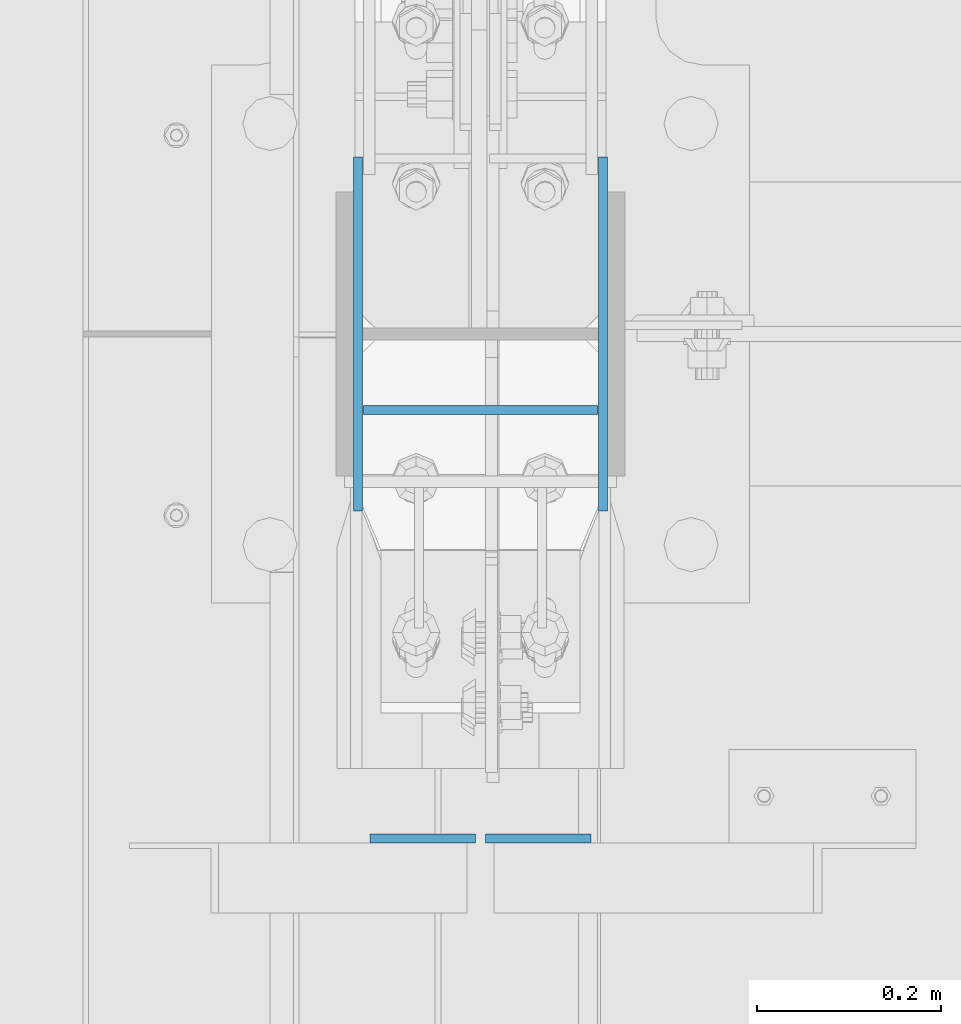
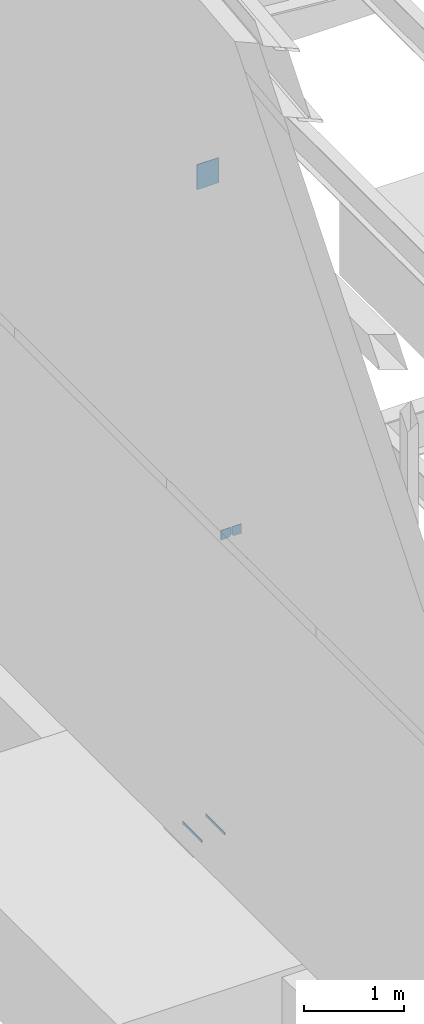
# One storey, part 387 of 1179: 5 columns, 3 elements without a shape of their own.
"""IFC2X3 building model written with IfcOpenShell, lengths in millimetres."""

from ifc_helpers import new_model, si_unit, frame, origin_with_axes, place, context, subcontext, project, spatial, faceted_brep, material, type_object, element, aggregate, save


model = new_model("IFC2X3")

# Units and contexts
model_context = context("Model", 3, precision=1e-05, world=origin_with_axes())
body_context = subcontext(model_context, "Body", "Model", "MODEL_VIEW")
ifc_project = project(units=[si_unit("LENGTHUNIT", "METRE", prefix="MILLI"), si_unit("AREAUNIT", "SQUARE_METRE"), si_unit("VOLUMEUNIT", "CUBIC_METRE"), si_unit("MASSUNIT", "GRAM", prefix="KILO"), si_unit("TIMEUNIT", "SECOND"), si_unit("PLANEANGLEUNIT", "RADIAN"), si_unit("SOLIDANGLEUNIT", "STERADIAN"), si_unit("THERMODYNAMICTEMPERATUREUNIT", "DEGREE_CELSIUS"), si_unit("LUMINOUSINTENSITYUNIT", "LUMEN")], contexts=[model_context])

# Site, building, storey
site_placement = place(None, origin_with_axes())
site = spatial("IfcSite", under=ifc_project, at=site_placement, CompositionType="ELEMENT")
building_placement = place(site_placement, origin_with_axes())
building = spatial("IfcBuilding", under=site, at=building_placement, Name="Undefined", CompositionType="ELEMENT")
storey_placement = place(building_placement, origin_with_axes())
storey = spatial("IfcBuildingStorey", under=building, at=storey_placement, Name="Undefined", CompositionType="ELEMENT", Elevation=0.0)

# Assembly, columns
assembly_1_placement = place(storey_placement, origin_with_axes())
assembly_1 = element("IfcElementAssembly", 1, at=assembly_1_placement, inside=storey, Name="BEAM", AssemblyPlace="NOTDEFINED", PredefinedType="RIGID_FRAME")
ifc_material_1 = material(Name="STEEL/A36")
column_type_1 = type_object("IfcColumnType", PredefinedType="NOTDEFINED")
column_1_placement = place(assembly_1_placement, frame((494.506249999995, 10933.1125, 3702.05), z_axis=(-1.0, 0.0, 0.0), x_axis=(0.0, 0.0, 1.0)))
column_1 = element("IfcColumn", 2, at=column_1_placement, type_object=column_type_1, material=ifc_material_1, Name="PLATE", context=body_context, shape_type="Brep", body=[
    faceted_brep([(22.2250000000004, 4.76250000000073, 57.1500000000015), (0.0, 4.76250000000073, 34.9249999999993), (0.0, -4.76250000000073, 34.9249999999993), (22.2250000000004, -4.76250000000073, 57.1500000000015), (114.300000000001, 4.76250000000073, 57.1500000000015), (114.300000000001, 4.76250000000073, -57.1500000000015), (0.0, 4.76250000000073, -57.1500000000015), (114.300000000001, -4.76250000000073, 57.1500000000015), (0.0, -4.76250000000073, -57.1500000000015), (114.300000000001, -4.76250000000073, -57.1500000000015)], [[[0, 1, 2, 3]], [[4, 5, 6, 1, 0]], [[7, 4, 0, 3]], [[8, 9, 7, 3, 2]], [[8, 6, 5, 9]], [[7, 9, 5, 4]], [[6, 8, 2, 1]]]),
])
column_2_placement = place(assembly_1_placement, frame((369.09375, 10933.1125, 3702.05), z_axis=(1.0, 0.0, 0.0), x_axis=(0.0, 0.0, 1.0)))
column_2 = element("IfcColumn", 3, at=column_2_placement, type_object=column_type_1, material=ifc_material_1, Name="PLATE", context=body_context, shape_type="Brep", body=[
    faceted_brep([(22.2250000000004, 4.76250000000073, 57.1500000000015), (0.0, 4.76250000000073, 34.9249999999993), (0.0, -4.76250000000073, 34.9249999999993), (22.2250000000004, -4.76250000000073, 57.1500000000015), (114.300000000001, 4.76250000000073, 57.1500000000015), (114.300000000001, 4.76250000000073, -57.1500000000015), (0.0, 4.76250000000073, -57.1500000000015), (114.300000000001, -4.76250000000073, 57.1500000000015), (0.0, -4.76250000000073, -57.1500000000015), (114.300000000001, -4.76250000000073, -57.1500000000015)], [[[0, 1, 2, 3]], [[4, 5, 6, 1, 0]], [[7, 4, 0, 3]], [[8, 9, 7, 3, 2]], [[8, 6, 5, 9]], [[7, 9, 5, 4]], [[6, 8, 2, 1]]]),
])
aggregate(assembly_1, [column_1, column_2])

assembly_2_placement = place(storey_placement, origin_with_axes())
assembly_2 = element("IfcElementAssembly", 4, at=assembly_2_placement, inside=storey, Name="COLUMN", AssemblyPlace="NOTDEFINED", PredefinedType="RIGID_FRAME")
ifc_material_2 = material(Name="STEEL/A572-GR.50")
column_type_2 = type_object("IfcColumnType", PredefinedType="NOTDEFINED")
column_3_placement = place(assembly_2_placement, frame((564.753000000002, 11480.8, -215.9), z_axis=(0.0, -1.0, 0.0), x_axis=(0.0, 0.0, 1.0)))
column_3 = element("IfcColumn", 5, at=column_3_placement, type_object=column_type_2, material=ifc_material_2, Name="PLATE", context=body_context, shape_type="Brep", body=[
    faceted_brep([(0.0, 4.76249999999982, -192.087500000001), (0.0, 4.76249999999982, 192.0875), (31.75, 4.76249999999982, 192.0875), (31.75, 4.76249999999982, -192.087500000001), (0.0, -4.76249999999982, 192.0875), (31.75, -4.76249999999982, 192.0875), (0.0, -4.76249999999982, -192.087500000001), (31.75, -4.76249999999982, -192.087500000001)], [[[0, 1, 2, 3]], [[1, 4, 5, 2]], [[4, 6, 7, 5]], [[6, 0, 3, 7]], [[5, 7, 3, 2]], [[6, 4, 1, 0]]]),
])
column_4_placement = place(assembly_2_placement, frame((298.846874999999, 11480.8, -215.9), z_axis=(0.0, -1.0, 0.0), x_axis=(0.0, 0.0, 1.0)))
column_4 = element("IfcColumn", 6, at=column_4_placement, type_object=column_type_2, material=ifc_material_2, Name="PLATE", context=body_context, shape_type="Brep", body=[
    faceted_brep([(0.0, 4.76249999999982, -192.087500000001), (0.0, 4.76249999999982, 192.0875), (31.75, 4.76249999999982, 192.0875), (31.75, 4.76249999999982, -192.087500000001), (0.0, -4.76249999999982, 192.0875), (31.75, -4.76249999999982, 192.0875), (0.0, -4.76249999999982, -192.087500000001), (31.75, -4.76249999999982, -192.087500000001)], [[[0, 1, 2, 3]], [[1, 4, 5, 2]], [[4, 6, 7, 5]], [[6, 0, 3, 7]], [[5, 7, 3, 2]], [[6, 4, 1, 0]]]),
])
aggregate(assembly_2, [column_3, column_4])

# Assembly, column
assembly_3_placement = place(storey_placement, origin_with_axes())
assembly_3 = element("IfcElementAssembly", 7, at=assembly_3_placement, inside=storey, Name="BEAM", AssemblyPlace="NOTDEFINED", PredefinedType="RIGID_FRAME")
column_type_3 = type_object("IfcColumnType", PredefinedType="NOTDEFINED")
column_5_placement = place(assembly_3_placement, frame((431.800000000005, 11398.25, 7708.9), z_axis=(-1.0, 0.0, 0.0), x_axis=(0.0, 0.0, 1.0)))
column_5 = element("IfcColumn", 8, at=column_5_placement, type_object=column_type_3, material=ifc_material_1, Name="PLATE", context=body_context, shape_type="Brep", body=[
    faceted_brep([(0.0, 4.76249999999982, -127.0), (0.0, 4.76249999999709, 127.0), (304.799999999999, 4.76249999999982, 127.0), (304.799999999999, 4.76249999999982, -127.0), (0.0, -4.76249999999709, 127.0), (304.799999999999, -4.76249999999982, 127.0), (0.0, -4.76249999999982, -127.0), (304.799999999999, -4.76249999999982, -127.0)], [[[0, 1, 2, 3]], [[1, 4, 5, 2]], [[4, 6, 7, 5]], [[6, 0, 3, 7]], [[5, 7, 3, 2]], [[6, 4, 1, 0]]]),
])
aggregate(assembly_3, [column_5])

save(model, "model.ifc")
